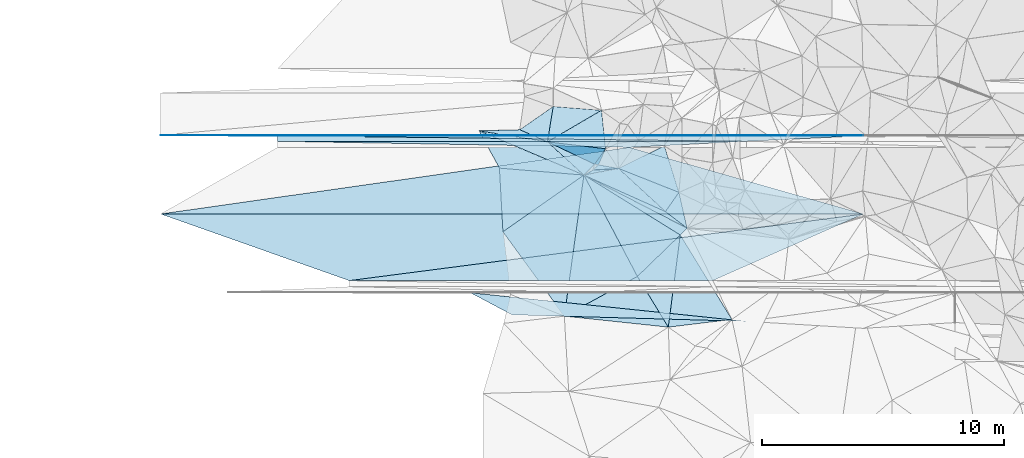
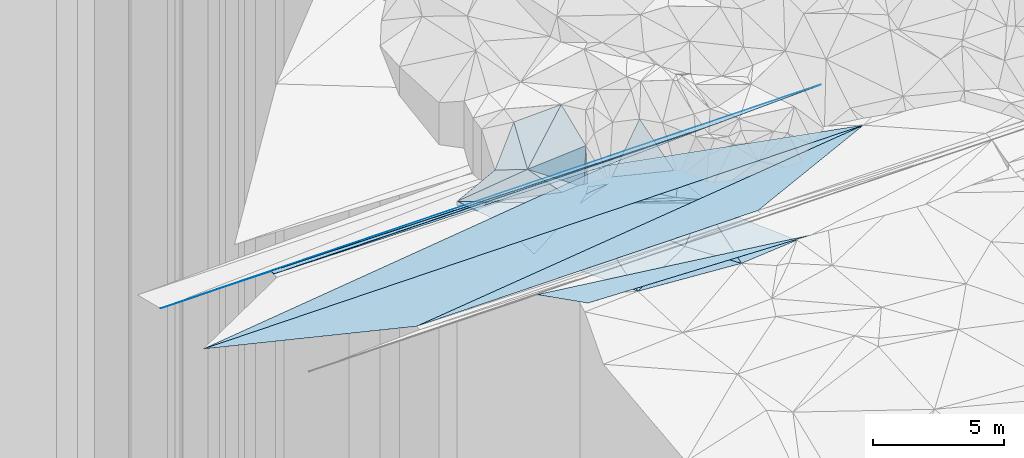
# One storey, part 45 of 275: 50 plates.
"""IFC2X3 building model written with IfcOpenShell, lengths in millimetres."""

from ifc_helpers import new_model, si_unit, frame, origin_with_axes, place, context, subcontext, project, spatial, polyline, outline, extrude, material, type_object, element, save


model = new_model("IFC2X3")

# Units and contexts
model_context = context("Model", 3, precision=1e-05, world=origin_with_axes())
body_context = subcontext(model_context, "Body", "Model", "MODEL_VIEW")
ifc_project = project(units=[si_unit("LENGTHUNIT", "METRE", prefix="MILLI"), si_unit("AREAUNIT", "SQUARE_METRE"), si_unit("VOLUMEUNIT", "CUBIC_METRE"), si_unit("MASSUNIT", "GRAM", prefix="KILO"), si_unit("TIMEUNIT", "SECOND"), si_unit("PLANEANGLEUNIT", "RADIAN"), si_unit("SOLIDANGLEUNIT", "STERADIAN"), si_unit("THERMODYNAMICTEMPERATUREUNIT", "DEGREE_CELSIUS"), si_unit("LUMINOUSINTENSITYUNIT", "LUMEN")], contexts=[model_context])

# Site, building, storey
site_placement = place(None, origin_with_axes())
site = spatial("IfcSite", under=ifc_project, at=site_placement, CompositionType="ELEMENT")
building_placement = place(site_placement, origin_with_axes())
building = spatial("IfcBuilding", under=site, at=building_placement, Name="Undefined", CompositionType="ELEMENT")
storey_placement = place(building_placement, origin_with_axes())
storey = spatial("IfcBuildingStorey", under=building, at=storey_placement, Name="Undefined", CompositionType="ELEMENT", Elevation=0.0)

# Plates
ifc_material = material()
plate_type_1 = type_object("IfcPlateType", PredefinedType="NOTDEFINED")
plate_1_placement = place(storey_placement, frame((-134278.700031969, 66044.5731858637, 48859.6831648337), z_axis=(0.00832149793297365, -0.0249918019511436, -0.9996530210565), x_axis=(0.96172712039003, -0.273606547074793, 0.0148459861279161)))
element("IfcPlate", 1, at=plate_1_placement, inside=storey, type_object=plate_type_1, material=ifc_material, Name="00_PR", context=body_context, shape_type="SweptSolid", body=[
    extrude(outline(polyline([(0.0, 0.0), (10052.953125, -1.1648444342427e-07), (-17846.044921875, 7937.130859375), (0.0, 0.0)])), frame((-8.85201319254618e-08, 2.18876761149539e-07, -0.5000001331573), z_axis=(0.0, 0.0, 1.0), x_axis=(1.0, 0.0, 0.0)), (0.0, 0.0, 1.0), 1.0),
])
plate_2_placement = place(storey_placement, frame((-153615.567535843, 63295.7070231726, 48767.4411626867), z_axis=(0.008324340579686, 0.024990848492353, -0.999653021225638), x_axis=(0.999965340787191, -5.73519775278889e-05, 0.0083254990906575)))
element("IfcPlate", 2, at=plate_2_placement, inside=storey, type_object=plate_type_1, material=ifc_material, Name="00_PR", context=body_context, shape_type="SweptSolid", body=[
    extrude(outline(polyline([(0.0, 0.0), (29006.0703125, -2.99005478154868e-07), (7784.8349609375, 2750.85961914063), (0.0, 0.0)])), frame((-8.85201319254618e-08, 2.18876761149539e-07, -0.5000001331573), z_axis=(0.0, 0.0, 1.0), x_axis=(1.0, 0.0, 0.0)), (0.0, 0.0, 1.0), 1.0),
])
plate_3_placement = place(storey_placement, frame((-134278.700031969, 66044.5731858637, 48859.6831648337), z_axis=(0.00832149793297365, -0.0249918019511436, -0.9996530210565), x_axis=(0.96172712039003, -0.273606547074793, 0.0148459861279161)))
element("IfcPlate", 3, at=plate_3_placement, inside=storey, type_object=plate_type_1, material=ifc_material, Name="00_PR", context=body_context, shape_type="SweptSolid", body=[
    extrude(outline(polyline([(0.0, 0.0), (10052.953125, -1.1648444342427e-07), (-17846.044921875, 7937.130859375), (0.0, 0.0)])), frame((-8.85201319254618e-08, 2.18876761149539e-07, -0.5000001331573), z_axis=(0.0, 0.0, 1.0), x_axis=(1.0, 0.0, 0.0)), (0.0, 0.0, 1.0), 1.0),
])
plate_4_placement = place(storey_placement, frame((-153615.567535843, 63295.7070231726, 48767.4411626867), z_axis=(0.008324340579686, 0.024990848492353, -0.999653021225638), x_axis=(0.999965340787191, -5.73519775278889e-05, 0.0083254990906575)))
element("IfcPlate", 4, at=plate_4_placement, inside=storey, type_object=plate_type_1, material=ifc_material, Name="00_PR", context=body_context, shape_type="SweptSolid", body=[
    extrude(outline(polyline([(0.0, 0.0), (29006.0703125, -2.99005478154868e-07), (7784.8349609375, 2750.85961914063), (0.0, 0.0)])), frame((-8.85201319254618e-08, 2.18876761149539e-07, -0.5000001331573), z_axis=(0.0, 0.0, 1.0), x_axis=(1.0, 0.0, 0.0)), (0.0, 0.0, 1.0), 1.0),
])
plate_5_placement = place(storey_placement, frame((-134278.700031969, 66044.5731858637, 48859.6831648337), z_axis=(0.00832149793297365, -0.0249918019511436, -0.9996530210565), x_axis=(0.96172712039003, -0.273606547074793, 0.0148459861279161)))
element("IfcPlate", 5, at=plate_5_placement, inside=storey, type_object=plate_type_1, material=ifc_material, Name="00_PR", context=body_context, shape_type="SweptSolid", body=[
    extrude(outline(polyline([(0.0, 0.0), (10052.953125, -1.1648444342427e-07), (-17846.044921875, 7937.130859375), (0.0, 0.0)])), frame((-8.85201319254618e-08, 2.18876761149539e-07, -0.5000001331573), z_axis=(0.0, 0.0, 1.0), x_axis=(1.0, 0.0, 0.0)), (0.0, 0.0, 1.0), 1.0),
])
plate_type_2 = type_object("IfcPlateType", PredefinedType="NOTDEFINED")
for number, where, z_axis, x_axis, name in (
    (6, (-148781.218091013, 66295.4040468256, 48732.6891635919), (0.00832149793297365, -0.0249918019511436, -0.9996530210565), (0.999965340787191, -5.73519775278889e-05, 0.0083254990906575), "00_PR"),
    (7, (-148781.218091013, 66295.4040468256, 48732.6891635919), (0.00832149793297365, -0.0249918019511436, -0.9996530210565), (0.999965340787191, -5.73519775278889e-05, 0.0083254990906575), "00_PR"),
    (8, (-148781.218091013, 66295.4040468256, 48732.6891635919), (0.00832149793297365, -0.0249918019511436, -0.9996530210565), (0.999965340787191, -5.73519775278889e-05, 0.0083254990906575), "00_PR"),
):
    element("IfcPlate", number, at=place(storey_placement, frame(where, z_axis=z_axis, x_axis=x_axis)), inside=storey, type_object=plate_type_2, material=ifc_material, Name=name, context=body_context, shape_type="SweptSolid", body=[
        extrude(outline(polyline([(0.0, 0.0), (19337.380859375, 2.13287421502173e-07), (14503.0869140625, 250.078308105469), (0.0, 0.0)])), frame((-8.85201319254618e-08, 2.18876761149539e-07, -0.5000001331573), z_axis=(0.0, 0.0, 1.0), x_axis=(1.0, 0.0, 0.0)), (0.0, 0.0, 1.0), 1.0),
    ])
plate_type_3 = type_object("IfcPlateType", PredefinedType="NOTDEFINED")
plate_6_placement = place(storey_placement, frame((-124610.316164566, 66544.0069396636, 48921.4296332488), z_axis=(0.0083122519702356, -0.0499355339048205, -0.998717852509318), x_axis=(-5.44309877651753e-05, -0.998752377894856, 0.0499368069327535)))
element("IfcPlate", 9, at=plate_6_placement, inside=storey, type_object=plate_type_3, material=ifc_material, Name="00_PR", context=body_context, shape_type="SweptSolid", body=[
    extrude(outline(polyline([(0.0, 0.0), (20.0253086090088, -9.45874489843845e-11), (9.90786075592041, 24171.724609375), (0.0, 0.0)])), frame((-8.85201319254618e-08, 2.18876761149539e-07, -0.5000001331573), z_axis=(0.0, 0.0, 1.0), x_axis=(1.0, 0.0, 0.0)), (0.0, 0.0, 1.0), 1.0),
])
plate_7_placement = place(storey_placement, frame((-124610.316164566, 66544.0069396636, 48921.4296332488), z_axis=(0.00831224750610881, -0.0499379782776763, -0.998717730325709), x_axis=(-0.999965390052114, -0.000770105057063823, -0.00828405915753017)))
element("IfcPlate", 10, at=plate_7_placement, inside=storey, type_object=plate_type_3, material=ifc_material, Name="00_PR", context=body_context, shape_type="SweptSolid", body=[
    extrude(outline(polyline([(0.0, 0.0), (24171.7265625, -1.47440005093813e-07), (29006.060546875, 24.0294322967529), (0.0, 0.0)])), frame((-8.85201319254618e-08, 2.18876761149539e-07, -0.5000001331573), z_axis=(0.0, 0.0, 1.0), x_axis=(1.0, 0.0, 0.0)), (0.0, 0.0, 1.0), 1.0),
])
plate_8_placement = place(storey_placement, frame((-124610.316164566, 66544.0069396636, 48921.4296332488), z_axis=(0.0083122519702356, -0.0499355339048205, -0.998717852509318), x_axis=(-5.44309877651753e-05, -0.998752377894856, 0.0499368069327535)))
element("IfcPlate", 11, at=plate_8_placement, inside=storey, type_object=plate_type_3, material=ifc_material, Name="00_PR", context=body_context, shape_type="SweptSolid", body=[
    extrude(outline(polyline([(0.0, 0.0), (20.0253086090088, -9.45874489843845e-11), (9.90786075592041, 24171.724609375), (0.0, 0.0)])), frame((-8.85201319254618e-08, 2.18876761149539e-07, -0.5000001331573), z_axis=(0.0, 0.0, 1.0), x_axis=(1.0, 0.0, 0.0)), (0.0, 0.0, 1.0), 1.0),
])
plate_9_placement = place(storey_placement, frame((-124610.316164566, 66544.0069396636, 48921.4296332488), z_axis=(0.00831224750610881, -0.0499379782776763, -0.998717730325709), x_axis=(-0.999965390052114, -0.000770105057063823, -0.00828405915753017)))
element("IfcPlate", 12, at=plate_9_placement, inside=storey, type_object=plate_type_3, material=ifc_material, Name="00_PR", context=body_context, shape_type="SweptSolid", body=[
    extrude(outline(polyline([(0.0, 0.0), (24171.7265625, -1.47440005093813e-07), (29006.060546875, 24.0294322967529), (0.0, 0.0)])), frame((-8.85201319254618e-08, 2.18876761149539e-07, -0.5000001331573), z_axis=(0.0, 0.0, 1.0), x_axis=(1.0, 0.0, 0.0)), (0.0, 0.0, 1.0), 1.0),
])
plate_10_placement = place(storey_placement, frame((-124610.316164566, 66544.0069396636, 48921.4296332488), z_axis=(0.0083122519702356, -0.0499355339048205, -0.998717852509318), x_axis=(-5.44309877651753e-05, -0.998752377894856, 0.0499368069327535)))
element("IfcPlate", 13, at=plate_10_placement, inside=storey, type_object=plate_type_3, material=ifc_material, Name="00_PR", context=body_context, shape_type="SweptSolid", body=[
    extrude(outline(polyline([(0.0, 0.0), (20.0253086090088, -9.45874489843845e-11), (9.90786075592041, 24171.724609375), (0.0, 0.0)])), frame((-8.85201319254618e-08, 2.18876761149539e-07, -0.5000001331573), z_axis=(0.0, 0.0, 1.0), x_axis=(1.0, 0.0, 0.0)), (0.0, 0.0, 1.0), 1.0),
])
plate_11_placement = place(storey_placement, frame((-124610.316164566, 66544.0069396636, 48921.4296332488), z_axis=(0.00831224750610881, -0.0499379782776763, -0.998717730325709), x_axis=(-0.999965390052114, -0.000770105057063823, -0.00828405915753017)))
element("IfcPlate", 14, at=plate_11_placement, inside=storey, type_object=plate_type_3, material=ifc_material, Name="00_PR", context=body_context, shape_type="SweptSolid", body=[
    extrude(outline(polyline([(0.0, 0.0), (24171.7265625, -1.47440005093813e-07), (29006.060546875, 24.0294322967529), (0.0, 0.0)])), frame((-8.85201319254618e-08, 2.18876761149539e-07, -0.5000001331573), z_axis=(0.0, 0.0, 1.0), x_axis=(1.0, 0.0, 0.0)), (0.0, 0.0, 1.0), 1.0),
])
plate_type_4 = type_object("IfcPlateType", PredefinedType="NOTDEFINED")
plate_12_placement = place(storey_placement, frame((-148781.205267724, 66525.3921623201, 48721.1896292991), z_axis=(0.0083122519702356, -0.0499355339048205, -0.998717852509318), x_axis=(0.999888808722703, -0.0119504599526109, 0.00891945615012869)))
element("IfcPlate", 15, at=plate_12_placement, inside=storey, type_object=plate_type_4, material=ifc_material, Name="00_PR", context=body_context, shape_type="SweptSolid", body=[
    extrude(outline(polyline([(0.0, 0.0), (19338.84765625, 1.70177372638136e-07), (2.83835864067078, 230.270416259766), (0.0, 0.0)])), frame((-8.85201319254618e-08, 2.18876761149539e-07, -0.5000001331573), z_axis=(0.0, 0.0, 1.0), x_axis=(1.0, 0.0, 0.0)), (0.0, 0.0, 1.0), 1.0),
])
plate_13_placement = place(storey_placement, frame((-124610.317251208, 66524.0066136166, 48922.4296326399), z_axis=(0.0083122519702356, -0.0499355339048205, -0.998717852509318), x_axis=(-0.998855193134605, -0.0474659830428806, -0.0059400001519148)))
element("IfcPlate", 16, at=plate_13_placement, inside=storey, type_object=plate_type_4, material=ifc_material, Name="00_PR", context=body_context, shape_type="SweptSolid", body=[
    extrude(outline(polyline([(0.0, 0.0), (4839.73095703125, -7.01402314007282e-09), (24144.345703125, 1150.15368652344), (0.0, 0.0)])), frame((-8.85201319254618e-08, 2.18876761149539e-07, -0.5000001331573), z_axis=(0.0, 0.0, 1.0), x_axis=(1.0, 0.0, 0.0)), (0.0, 0.0, 1.0), 1.0),
])
plate_14_placement = place(storey_placement, frame((-148781.205267724, 66525.3921623201, 48721.1896292991), z_axis=(0.0083122519702356, -0.0499355339048205, -0.998717852509318), x_axis=(0.999888808722703, -0.0119504599526109, 0.00891945615012869)))
element("IfcPlate", 17, at=plate_14_placement, inside=storey, type_object=plate_type_4, material=ifc_material, Name="00_PR", context=body_context, shape_type="SweptSolid", body=[
    extrude(outline(polyline([(0.0, 0.0), (19338.84765625, 1.70177372638136e-07), (2.83835864067078, 230.270416259766), (0.0, 0.0)])), frame((-8.85201319254618e-08, 2.18876761149539e-07, -0.5000001331573), z_axis=(0.0, 0.0, 1.0), x_axis=(1.0, 0.0, 0.0)), (0.0, 0.0, 1.0), 1.0),
])
plate_15_placement = place(storey_placement, frame((-124610.317251208, 66524.0066136166, 48922.4296326399), z_axis=(0.0083122519702356, -0.0499355339048205, -0.998717852509318), x_axis=(-0.998855193134605, -0.0474659830428806, -0.0059400001519148)))
element("IfcPlate", 18, at=plate_15_placement, inside=storey, type_object=plate_type_4, material=ifc_material, Name="00_PR", context=body_context, shape_type="SweptSolid", body=[
    extrude(outline(polyline([(0.0, 0.0), (4839.73095703125, -7.01402314007282e-09), (24144.345703125, 1150.15368652344), (0.0, 0.0)])), frame((-8.85201319254618e-08, 2.18876761149539e-07, -0.5000001331573), z_axis=(0.0, 0.0, 1.0), x_axis=(1.0, 0.0, 0.0)), (0.0, 0.0, 1.0), 1.0),
])
plate_16_placement = place(storey_placement, frame((-148781.205267724, 66525.3921623201, 48721.1896292991), z_axis=(0.0083122519702356, -0.0499355339048205, -0.998717852509318), x_axis=(0.999888808722703, -0.0119504599526109, 0.00891945615012869)))
element("IfcPlate", 19, at=plate_16_placement, inside=storey, type_object=plate_type_4, material=ifc_material, Name="00_PR", context=body_context, shape_type="SweptSolid", body=[
    extrude(outline(polyline([(0.0, 0.0), (19338.84765625, 1.70177372638136e-07), (2.83835864067078, 230.270416259766), (0.0, 0.0)])), frame((-8.85201319254618e-08, 2.18876761149539e-07, -0.5000001331573), z_axis=(0.0, 0.0, 1.0), x_axis=(1.0, 0.0, 0.0)), (0.0, 0.0, 1.0), 1.0),
])
plate_17_placement = place(storey_placement, frame((-124610.317251208, 66524.0066136166, 48922.4296326399), z_axis=(0.0083122519702356, -0.0499355339048205, -0.998717852509318), x_axis=(-0.998855193134605, -0.0474659830428806, -0.0059400001519148)))
element("IfcPlate", 20, at=plate_17_placement, inside=storey, type_object=plate_type_4, material=ifc_material, Name="00_PR", context=body_context, shape_type="SweptSolid", body=[
    extrude(outline(polyline([(0.0, 0.0), (4839.73095703125, -7.01402314007282e-09), (24144.345703125, 1150.15368652344), (0.0, 0.0)])), frame((-8.85201319254618e-08, 2.18876761149539e-07, -0.5000001331573), z_axis=(0.0, 0.0, 1.0), x_axis=(1.0, 0.0, 0.0)), (0.0, 0.0, 1.0), 1.0),
])
plate_type_5 = type_object("IfcPlateType", PredefinedType="NOTDEFINED")
plate_18_placement = place(storey_placement, frame((-137650.45517658, 66271.2889370245, 49719.6899600449), z_axis=(0.288448435040954, 0.729610402389059, -0.620053353388319), x_axis=(-0.952822303943619, 0.154822959794669, -0.261073760129186)))
element("IfcPlate", 21, at=plate_18_placement, inside=storey, type_object=plate_type_5, material=ifc_material, Name="00", context=body_context, shape_type="SweptSolid", body=[
    extrude(outline(polyline([(0.0, 0.0), (2964.67944335938, -1.7811544239521e-08), (1148.4951171875, 486.373138427734), (0.0, 0.0)])), frame((-8.85201319254618e-08, 2.18876761149539e-07, -0.5000001331573), z_axis=(0.0, 0.0, 1.0), x_axis=(1.0, 0.0, 0.0)), (0.0, 0.0, 1.0), 1.0),
])
plate_type_6 = type_object("IfcPlateType", PredefinedType="NOTDEFINED")
for number, where, z_axis, x_axis, name in (
    (22, (-129444.933998013, 58865.854445659, 48291.8947907505), (0.00747221277555471, 0.447200796920443, -0.894402377719311), (-0.999598991124094, 0.0277709789710622, 0.00553440788902316), "00_PR"),
    (23, (-129444.933998013, 58865.854445659, 48291.8947907505), (0.00747221277555471, 0.447200796920443, -0.894402377719311), (-0.999598991124094, 0.0277709789710622, 0.00553440788902316), "00_PR"),
    (24, (-129444.933998013, 58865.854445659, 48291.8947907505), (0.00747221277555471, 0.447200796920443, -0.894402377719311), (-0.999598991124094, 0.0277709789710622, 0.00553440788902316), "00_PR"),
):
    element("IfcPlate", number, at=place(storey_placement, frame(where, z_axis=z_axis, x_axis=x_axis)), inside=storey, type_object=plate_type_6, material=ifc_material, Name=name, context=body_context, shape_type="SweptSolid", body=[
        extrude(outline(polyline([(0.0, 0.0), (9672.2177734375, 4.66534402221441e-08), (11416.6044921875, 964.516784667969), (0.0, 0.0)])), frame((-8.85201319254618e-08, 2.18876761149539e-07, -0.5000001331573), z_axis=(0.0, 0.0, 1.0), x_axis=(1.0, 0.0, 0.0)), (0.0, 0.0, 1.0), 1.0),
    ])
plate_type_7 = type_object("IfcPlateType", PredefinedType="NOTDEFINED")
for number, where, z_axis, x_axis, name in (
    (25, (-145830.587496923, 60545.2603882401, 48763.5081632903), (0.008324340579686, 0.024990848492353, -0.999653021225638), (0.991649001469661, 0.128455135095925, 0.0114689211224232), "00_PR"),
    (26, (-145830.587496923, 60545.2603882401, 48763.5081632903), (0.008324340579686, 0.024990848492353, -0.999653021225638), (0.991649001469661, 0.128455135095925, 0.0114689211224232), "00_PR"),
    (27, (-145830.587496923, 60545.2603882401, 48763.5081632903), (0.008324340579686, 0.024990848492353, -0.999653021225638), (0.991649001469661, 0.128455135095925, 0.0114689211224232), "00_PR"),
):
    element("IfcPlate", number, at=place(storey_placement, frame(where, z_axis=z_axis, x_axis=x_axis)), inside=storey, type_object=plate_type_7, material=ifc_material, Name=name, context=body_context, shape_type="SweptSolid", body=[
        extrude(outline(polyline([(0.0, 0.0), (21398.787109375, -1.86744728125632e-07), (14876.056640625, 1928.34838867188), (0.0, 0.0)])), frame((-8.85201319254618e-08, 2.18876761149539e-07, -0.5000001331573), z_axis=(0.0, 0.0, 1.0), x_axis=(1.0, 0.0, 0.0)), (0.0, 0.0, 1.0), 1.0),
    ])
plate_type_8 = type_object("IfcPlateType", PredefinedType="NOTDEFINED")
plate_19_placement = place(storey_placement, frame((-132662.983498364, 58624.693817771, 48239.5000497586), z_axis=(0.0152769969749297, -0.00979966811400198, -0.999835276367204), x_axis=(-0.994312009886558, 0.105263471335527, -0.0162243211799136)))
element("IfcPlate", 28, at=plate_19_placement, inside=storey, type_object=plate_type_8, material=ifc_material, Name="00", context=body_context, shape_type="SweptSolid", body=[
    extrude(outline(polyline([(0.0, 0.0), (4314.51025390625, -1.97105691768229e-08), (1488.95227050781, 1947.28564453125), (0.0, 0.0)])), frame((-8.85201319254618e-08, 2.18876761149539e-07, -0.5000001331573), z_axis=(0.0, 0.0, 1.0), x_axis=(1.0, 0.0, 0.0)), (0.0, 0.0, 1.0), 1.0),
])
plate_type_9 = type_object("IfcPlateType", PredefinedType="NOTDEFINED")
plate_20_placement = place(storey_placement, frame((-140475.445953107, 66729.9882039977, 48945.5051966263), z_axis=(-0.0675890501384564, 0.127256087754838, -0.989564352849634), x_axis=(0.915303983655303, -0.386802950532868, -0.112259052925816)))
element("IfcPlate", 29, at=plate_20_placement, inside=storey, type_object=plate_type_9, material=ifc_material, Name="00", context=body_context, shape_type="SweptSolid", body=[
    extrude(outline(polyline([(0.0, 0.0), (4730.130859375, 4.99640009365976e-08), (1397.70849609375, 1096.97534179688), (0.0, 0.0)])), frame((-8.85201319254618e-08, 2.18876761149539e-07, -0.5000001331573), z_axis=(0.0, 0.0, 1.0), x_axis=(1.0, 0.0, 0.0)), (0.0, 0.0, 1.0), 1.0),
])
plate_type_10 = type_object("IfcPlateType", PredefinedType="NOTDEFINED")
plate_21_placement = place(storey_placement, frame((-136145.973073215, 64900.1561043211, 48414.5248634539), z_axis=(-0.136868968140562, -0.279872738758356, -0.950230569735596), x_axis=(0.889168688372587, -0.457530737393946, 0.00668340912446974)))
element("IfcPlate", 30, at=plate_21_placement, inside=storey, type_object=plate_type_10, material=ifc_material, Name="00", context=body_context, shape_type="SweptSolid", body=[
    extrude(outline(polyline([(0.0, 0.0), (4787.97607421875, 6.50056790618692e-08), (4667.6015625, 397.477081298828), (0.0, 0.0)])), frame((-8.85201319254618e-08, 2.18876761149539e-07, -0.5000001331573), z_axis=(0.0, 0.0, 1.0), x_axis=(1.0, 0.0, 0.0)), (0.0, 0.0, 1.0), 1.0),
])
plate_type_11 = type_object("IfcPlateType", PredefinedType="NOTDEFINED")
plate_22_placement = place(storey_placement, frame((-135546.577102234, 65320.9328154775, 48749.7767860032), z_axis=(0.112574355321948, 0.887722421193144, -0.446403312526723), x_axis=(-0.974375206191429, 0.186667956817207, 0.125491160872389)))
element("IfcPlate", 31, at=plate_22_placement, inside=storey, type_object=plate_type_11, material=ifc_material, Name="00", context=body_context, shape_type="SweptSolid", body=[
    extrude(outline(polyline([(0.0, 0.0), (159.373779296875, 9.02218744158745e-10), (11.9216604232788, 1578.46691894531), (0.0, 0.0)])), frame((-8.85201319254618e-08, 2.18876761149539e-07, -0.5000001331573), z_axis=(0.0, 0.0, 1.0), x_axis=(1.0, 0.0, 0.0)), (0.0, 0.0, 1.0), 1.0),
])
plate_type_12 = type_object("IfcPlateType", PredefinedType="NOTDEFINED")
plate_23_placement = place(storey_placement, frame((-135546.613444, 65320.7704343892, 48749.5872245282), z_axis=(0.0398966074837302, 0.562957538075422, -0.825522301961218), x_axis=(0.982237248686457, -0.173699449749003, -0.0709823108228572)))
element("IfcPlate", 32, at=plate_23_placement, inside=storey, type_object=plate_type_12, material=ifc_material, Name="00", context=body_context, shape_type="SweptSolid", body=[
    extrude(outline(polyline([(0.0, 0.0), (845.281005859375, 6.63567334413528e-09), (-165.625396728516, 288.90869140625), (0.0, 0.0)])), frame((-8.85201319254618e-08, 2.18876761149539e-07, -0.5000001331573), z_axis=(0.0, 0.0, 1.0), x_axis=(1.0, 0.0, 0.0)), (0.0, 0.0, 1.0), 1.0),
])
plate_type_13 = type_object("IfcPlateType", PredefinedType="NOTDEFINED")
plate_24_placement = place(storey_placement, frame((-137650.534228711, 66271.2370317636, 49719.6154690165), z_axis=(0.130346321942666, 0.625795484622311, -0.769018756456788), x_axis=(0.124371036754945, 0.759189060193878, 0.638876996062963)))
element("IfcPlate", 33, at=plate_24_placement, inside=storey, type_object=plate_type_13, material=ifc_material, Name="00", context=body_context, shape_type="SweptSolid", body=[
    extrude(outline(polyline([(0.0, 0.0), (1925.25317382813, -1.33586581796408e-08), (2188.02392578125, 1993.77819824219), (0.0, 0.0)])), frame((-8.85201319254618e-08, 2.18876761149539e-07, -0.5000001331573), z_axis=(0.0, 0.0, 1.0), x_axis=(1.0, 0.0, 0.0)), (0.0, 0.0, 1.0), 1.0),
])
plate_type_14 = type_object("IfcPlateType", PredefinedType="NOTDEFINED")
plate_25_placement = place(storey_placement, frame((-135701.952767731, 65350.5657283856, 48769.622707786), z_axis=(-0.0590472616682201, 0.653590118823747, -0.754541832813427), x_axis=(-0.612406635974096, -0.620629782326255, -0.489670078220588)))
element("IfcPlate", 34, at=plate_25_placement, inside=storey, type_object=plate_type_14, material=ifc_material, Name="00", context=body_context, shape_type="SweptSolid", body=[
    extrude(outline(polyline([(0.0, 0.0), (724.977905273438, -3.28873284161091e-09), (156.790985107422, 2350.08862304688), (0.0, 0.0)])), frame((-8.85201319254618e-08, 2.18876761149539e-07, -0.5000001331573), z_axis=(0.0, 0.0, 1.0), x_axis=(1.0, 0.0, 0.0)), (0.0, 0.0, 1.0), 1.0),
])
plate_type_15 = type_object("IfcPlateType", PredefinedType="NOTDEFINED")
plate_26_placement = place(storey_placement, frame((-137411.040568195, 67732.8579376766, 50949.6183692649), z_axis=(0.226180068647366, 0.605233063003106, -0.763240143070679), x_axis=(-0.124371036778983, -0.759189060154258, -0.638876996105366)))
element("IfcPlate", 35, at=plate_26_placement, inside=storey, type_object=plate_type_15, material=ifc_material, Name="00", context=body_context, shape_type="SweptSolid", body=[
    extrude(outline(polyline([(0.0, 0.0), (1925.25317382813, -1.33586581796408e-08), (1647.783203125, 1215.98120117188), (0.0, 0.0)])), frame((-8.85201319254618e-08, 2.18876761149539e-07, -0.5000001331573), z_axis=(0.0, 0.0, 1.0), x_axis=(1.0, 0.0, 0.0)), (0.0, 0.0, 1.0), 1.0),
])
plate_type_16 = type_object("IfcPlateType", PredefinedType="NOTDEFINED")
plate_27_placement = place(storey_placement, frame((-135250.781243503, 65987.4259255906, 50149.7694896379), z_axis=(0.185286570532623, 0.8678428599384, -0.460996374426304), x_axis=(-0.284512861729786, -0.40165102900939, -0.870476238852058)))
element("IfcPlate", 36, at=plate_27_placement, inside=storey, type_object=plate_type_16, material=ifc_material, Name="00", context=body_context, shape_type="SweptSolid", body=[
    extrude(outline(polyline([(0.0, 0.0), (1585.33911132813, 5.6170392781496e-09), (943.015930175781, 2266.03637695313), (0.0, 0.0)])), frame((-8.85201319254618e-08, 2.18876761149539e-07, -0.5000001331573), z_axis=(0.0, 0.0, 1.0), x_axis=(1.0, 0.0, 0.0)), (0.0, 0.0, 1.0), 1.0),
])
plate_type_17 = type_object("IfcPlateType", PredefinedType="NOTDEFINED")
plate_28_placement = place(storey_placement, frame((-132781.509292209, 63394.1432066687, 48449.5177842331), z_axis=(0.104030813899555, 0.243157540512159, -0.964392036596878), x_axis=(-0.732954521789949, 0.674174714563675, 0.0909182227644974)))
element("IfcPlate", 37, at=plate_28_placement, inside=storey, type_object=plate_type_17, material=ifc_material, Name="00", context=body_context, shape_type="SweptSolid", body=[
    extrude(outline(polyline([(0.0, 0.0), (2639.73486328125, 1.39771145768464e-08), (149.977188110352, 991.97119140625), (0.0, 0.0)])), frame((-8.85201319254618e-08, 2.18876761149539e-07, -0.5000001331573), z_axis=(0.0, 0.0, 1.0), x_axis=(1.0, 0.0, 0.0)), (0.0, 0.0, 1.0), 1.0),
])
plate_type_18 = type_object("IfcPlateType", PredefinedType="NOTDEFINED")
plate_29_placement = place(storey_placement, frame((-136145.838801771, 64900.4317983634, 48414.5232751958), z_axis=(0.13148410669797, 0.271523154535864, -0.953408153015659), x_axis=(0.965125783925197, 0.184559373174594, 0.185661140188721)))
element("IfcPlate", 38, at=plate_29_placement, inside=storey, type_object=plate_type_18, material=ifc_material, Name="00", context=body_context, shape_type="SweptSolid", body=[
    extrude(outline(polyline([(0.0, 0.0), (1481.19311523438, -1.16124283522367e-08), (2975.51538085938, 2176.05151367188), (0.0, 0.0)])), frame((-8.85201319254618e-08, 2.18876761149539e-07, -0.5000001331573), z_axis=(0.0, 0.0, 1.0), x_axis=(1.0, 0.0, 0.0)), (0.0, 0.0, 1.0), 1.0),
])
plate_type_19 = type_object("IfcPlateType", PredefinedType="NOTDEFINED")
plate_30_placement = place(storey_placement, frame((-132224.469039701, 64187.2775104487, 48709.6685042232), z_axis=(0.280237631301984, 0.694235179405743, -0.662951269459324), x_axis=(-0.929727985598173, 0.368171407058372, -0.00746242723390273)))
element("IfcPlate", 39, at=plate_30_placement, inside=storey, type_object=plate_type_19, material=ifc_material, Name="00", context=body_context, shape_type="SweptSolid", body=[
    extrude(outline(polyline([(0.0, 0.0), (2680.09326171875, 2.11148289963603e-08), (1250.85192871094, 2363.4443359375), (0.0, 0.0)])), frame((-8.85201319254618e-08, 2.18876761149539e-07, -0.5000001331573), z_axis=(0.0, 0.0, 1.0), x_axis=(1.0, 0.0, 0.0)), (0.0, 0.0, 1.0), 1.0),
])
plate_type_20 = type_object("IfcPlateType", PredefinedType="NOTDEFINED")
plate_31_placement = place(storey_placement, frame((-132224.531327365, 64187.0340676987, 48709.517078719), z_axis=(0.15566715560969, 0.207349717743936, -0.965802169813207), x_axis=(0.218526870265599, -0.960724789274476, -0.171037674929929)))
element("IfcPlate", 40, at=plate_31_placement, inside=storey, type_object=plate_type_20, material=ifc_material, Name="00", context=body_context, shape_type="SweptSolid", body=[
    extrude(outline(polyline([(0.0, 0.0), (1537.67297363281, 6.49015419185162e-09), (684.527893066406, 733.431335449219), (0.0, 0.0)])), frame((-8.85201319254618e-08, 2.18876761149539e-07, -0.5000001331573), z_axis=(0.0, 0.0, 1.0), x_axis=(1.0, 0.0, 0.0)), (0.0, 0.0, 1.0), 1.0),
])
plate_type_21 = type_object("IfcPlateType", PredefinedType="NOTDEFINED")
plate_32_placement = place(storey_placement, frame((-134716.350050918, 65173.9720015623, 48689.6063825901), z_axis=(0.033676317820739, 0.615786819658532, -0.787192796176939), x_axis=(-0.965125783927773, -0.184559373170386, -0.185661140179508)))
element("IfcPlate", 41, at=plate_32_placement, inside=storey, type_object=plate_type_21, material=ifc_material, Name="00", context=body_context, shape_type="SweptSolid", body=[
    extrude(outline(polyline([(0.0, 0.0), (1481.19311523438, -1.16124283522367e-08), (1036.83312988281, 174.290481567383), (0.0, 0.0)])), frame((-8.85201319254618e-08, 2.18876761149539e-07, -0.5000001331573), z_axis=(0.0, 0.0, 1.0), x_axis=(1.0, 0.0, 0.0)), (0.0, 0.0, 1.0), 1.0),
])
plate_type_22 = type_object("IfcPlateType", PredefinedType="NOTDEFINED")
plate_33_placement = place(storey_placement, frame((-131888.571462102, 62709.6714673724, 48446.5006655904), z_axis=(0.0296980272982597, 0.0431278476243935, -0.998628066866678), x_axis=(-0.889168688122643, 0.457530737878346, -0.00668340921647804)))
element("IfcPlate", 42, at=plate_33_placement, inside=storey, type_object=plate_type_22, material=ifc_material, Name="00", context=body_context, shape_type="SweptSolid", body=[
    extrude(outline(polyline([(0.0, 0.0), (4787.97607421875, 6.50056790618692e-08), (1107.1064453125, 200.233108520508), (0.0, 0.0)])), frame((-8.85201319254618e-08, 2.18876761149539e-07, -0.5000001331573), z_axis=(0.0, 0.0, 1.0), x_axis=(1.0, 0.0, 0.0)), (0.0, 0.0, 1.0), 1.0),
])
plate_type_23 = type_object("IfcPlateType", PredefinedType="NOTDEFINED")
plate_34_placement = place(storey_placement, frame((-135417.213671474, 67575.5933512488, 51159.5925145886), z_axis=(0.209940477483669, 0.540202234554174, -0.814927322953775), x_axis=(0.0880845052224671, -0.84056340572274, -0.534503770706533)))
element("IfcPlate", 43, at=plate_34_placement, inside=storey, type_object=plate_type_23, material=ifc_material, Name="00", context=body_context, shape_type="SweptSolid", body=[
    extrude(outline(polyline([(0.0, 0.0), (1889.60314941406, -3.17231751978397e-09), (1669.39819335938, 2444.52661132813), (0.0, 0.0)])), frame((-8.85201319254618e-08, 2.18876761149539e-07, -0.5000001331573), z_axis=(0.0, 0.0, 1.0), x_axis=(1.0, 0.0, 0.0)), (0.0, 0.0, 1.0), 1.0),
])
plate_type_24 = type_object("IfcPlateType", PredefinedType="NOTDEFINED")
plate_35_placement = place(storey_placement, frame((-136145.766991783, 64900.6980219217, 48414.7363715795), z_axis=(0.27509312256573, 0.803970998043925, -0.527213816417297), x_axis=(-0.915303983464452, 0.386802951014694, 0.112259052821724)))
element("IfcPlate", 44, at=plate_35_placement, inside=storey, type_object=plate_type_24, material=ifc_material, Name="00", context=body_context, shape_type="SweptSolid", body=[
    extrude(outline(polyline([(0.0, 0.0), (4730.130859375, 4.99640009365976e-08), (2053.91430664063, 1275.61328125), (0.0, 0.0)])), frame((-8.85201319254618e-08, 2.18876761149539e-07, -0.5000001331573), z_axis=(0.0, 0.0, 1.0), x_axis=(1.0, 0.0, 0.0)), (0.0, 0.0, 1.0), 1.0),
])
plate_type_25 = type_object("IfcPlateType", PredefinedType="NOTDEFINED")
plate_36_placement = place(storey_placement, frame((-132169.099154248, 62429.2876105007, 48569.5061405877), z_axis=(0.141454217933823, 0.067306877599672, -0.987654032774895), x_axis=(-0.128244064383816, -0.988032868394512, -0.0857001220677862)))
element("IfcPlate", 45, at=plate_36_placement, inside=storey, type_object=plate_type_25, material=ifc_material, Name="00", context=body_context, shape_type="SweptSolid", body=[
    extrude(outline(polyline([(0.0, 0.0), (3850.63623046875, 1.7491402104497e-08), (1949.54797363281, 1547.50219726563), (0.0, 0.0)])), frame((-8.85201319254618e-08, 2.18876761149539e-07, -0.5000001331573), z_axis=(0.0, 0.0, 1.0), x_axis=(1.0, 0.0, 0.0)), (0.0, 0.0, 1.0), 1.0),
])
plate_type_26 = type_object("IfcPlateType", PredefinedType="NOTDEFINED")
plate_37_placement = place(storey_placement, frame((-133938.227348938, 60717.8261532693, 48199.5004998096), z_axis=(-0.0139675338677115, 0.0439773938167584, -0.998934881176316), x_axis=(-0.878529879896536, -0.477607392684809, -0.00874234418199501)))
element("IfcPlate", 46, at=plate_37_placement, inside=storey, type_object=plate_type_26, material=ifc_material, Name="00", context=body_context, shape_type="SweptSolid", body=[
    extrude(outline(polyline([(0.0, 0.0), (3431.57397460938, -2.89437593892217e-08), (-59.9520797729492, 4733.892578125), (0.0, 0.0)])), frame((-8.85201319254618e-08, 2.18876761149539e-07, -0.5000001331573), z_axis=(0.0, 0.0, 1.0), x_axis=(1.0, 0.0, 0.0)), (0.0, 0.0, 1.0), 1.0),
])
plate_type_27 = type_object("IfcPlateType", PredefinedType="NOTDEFINED")
plate_38_placement = place(storey_placement, frame((-136145.961053139, 64900.3247432412, 48414.5039934866), z_axis=(-0.112902017518181, 0.0573990969911353, -0.991946812135069), x_axis=(-0.137202666342392, -0.98966692703103, -0.0416509530442619)))
element("IfcPlate", 47, at=plate_38_placement, inside=storey, type_object=plate_type_27, material=ifc_material, Name="00", context=body_context, shape_type="SweptSolid", body=[
    extrude(outline(polyline([(0.0, 0.0), (5882.21826171875, -4.71482053399086e-09), (2763.00219726563, 3010.44702148438), (0.0, 0.0)])), frame((-8.85201319254618e-08, 2.18876761149539e-07, -0.5000001331573), z_axis=(0.0, 0.0, 1.0), x_axis=(1.0, 0.0, 0.0)), (0.0, 0.0, 1.0), 1.0),
])
plate_type_28 = type_object("IfcPlateType", PredefinedType="NOTDEFINED")
plate_39_placement = place(storey_placement, frame((-139631.679345667, 65187.3792370481, 48689.5015183534), z_axis=(-0.0780650145091753, 0.00710535560538799, -0.996922949596108), x_axis=(0.993559260270787, -0.0818279593440076, -0.0783848288877549)))
element("IfcPlate", 48, at=plate_39_placement, inside=storey, type_object=plate_type_28, material=ifc_material, Name="00", context=body_context, shape_type="SweptSolid", body=[
    extrude(outline(polyline([(0.0, 0.0), (3508.33203125, 1.99070200324059e-08), (360.402038574219, 2605.28515625), (0.0, 0.0)])), frame((-8.85201319254618e-08, 2.18876761149539e-07, -0.5000001331573), z_axis=(0.0, 0.0, 1.0), x_axis=(1.0, 0.0, 0.0)), (0.0, 0.0, 1.0), 1.0),
])
plate_type_29 = type_object("IfcPlateType", PredefinedType="NOTDEFINED")
plate_40_placement = place(storey_placement, frame((-136145.852453277, 64900.3489998151, 48414.5055378476), z_axis=(0.104357900336284, 0.105917546293347, -0.988883664555442), x_axis=(0.848914291466017, -0.527493808495473, 0.033087879105369)))
element("IfcPlate", 49, at=plate_40_placement, inside=storey, type_object=plate_type_29, material=ifc_material, Name="00", context=body_context, shape_type="SweptSolid", body=[
    extrude(outline(polyline([(0.0, 0.0), (4684.4951171875, -3.48409230355173e-08), (4073.25927734375, 2412.85961914063), (0.0, 0.0)])), frame((-8.85201319254618e-08, 2.18876761149539e-07, -0.5000001331573), z_axis=(0.0, 0.0, 1.0), x_axis=(1.0, 0.0, 0.0)), (0.0, 0.0, 1.0), 1.0),
])
plate_type_30 = type_object("IfcPlateType", PredefinedType="NOTDEFINED")
plate_41_placement = place(storey_placement, frame((-130037.701595284, 58943.4851274197, 48209.5020992676), z_axis=(-0.0222152813933587, 0.0892539414515035, -0.995761123567287), x_axis=(-0.992646247655129, -0.120518704670409, 0.0113432288507027)))
element("IfcPlate", 50, at=plate_41_placement, inside=storey, type_object=plate_type_30, material=ifc_material, Name="00", context=body_context, shape_type="SweptSolid", body=[
    extrude(outline(polyline([(0.0, 0.0), (2644.74951171875, 5.12227416038513e-09), (1699.78295898438, 3732.88598632813), (0.0, 0.0)])), frame((-8.85201319254618e-08, 2.18876761149539e-07, -0.5000001331573), z_axis=(0.0, 0.0, 1.0), x_axis=(1.0, 0.0, 0.0)), (0.0, 0.0, 1.0), 1.0),
])

save(model, "model.ifc")
